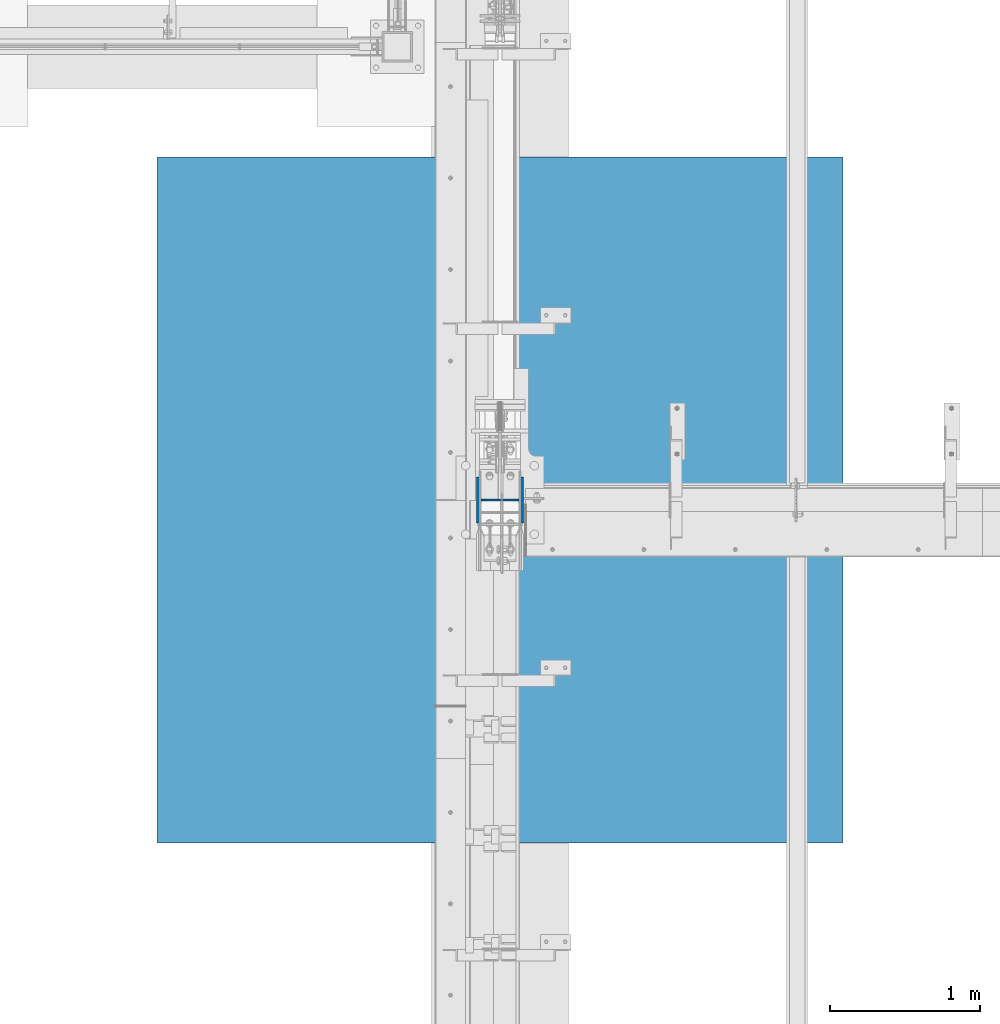
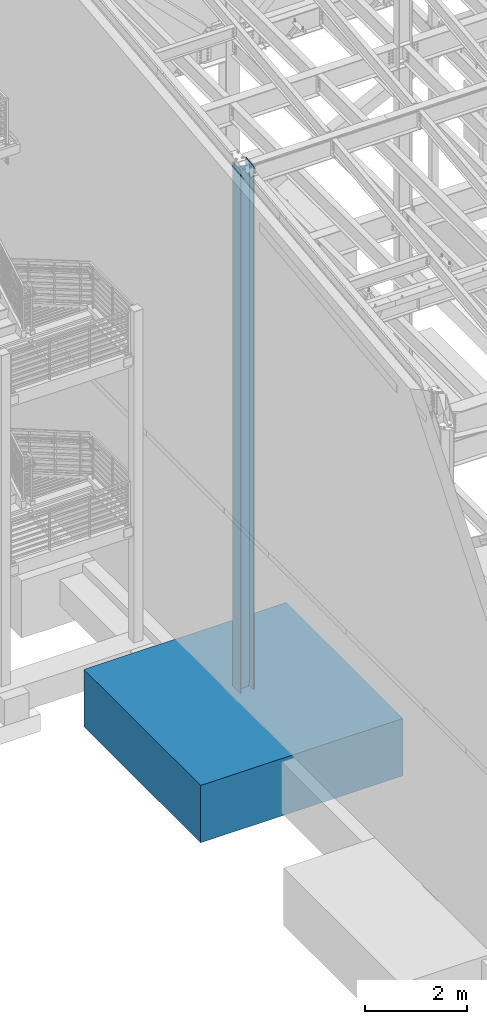
# One storey, part 357 of 1179: 2 columns, 2 elements without a shape of their own.
"""IFC2X3 building model written with IfcOpenShell, lengths in millimetres."""

import ifcopenshell
import ifcopenshell.guid

model = None  # the IFC model being written
_history = None  # IfcOwnerHistory: only IFC2X3 demands one
_inside = {}  # id of a spatial element -> (the spatial element, [elements in it])
_under = {}  # id of a project, library or spatial element -> (it, [spatial elements below it])
_declared = {}  # id of a project -> (the project, [libraries it declares])
_typed = {}  # id of a type object -> (the type object, [elements of that type])
_made_of = {}  # id of a material, layer set ... -> (it, [elements and type objects made of it])


def new_model(schema):
    """Start an empty IFC model of exactly this schema.

    Asked for "IFC4X3", IfcOpenShell would pick the latest addendum, in which some entities
    have other attributes; the version numbers below select the first issue.
    IFC2X3 requires an IfcOwnerHistory on every rooted entity: one is made here for all.
    """
    global model, _history
    if schema == "IFC4X3":
        model = ifcopenshell.file(schema_version=(4, 3, 0, 0))
    else:
        model = ifcopenshell.file(schema=schema)
    _inside.clear()
    _under.clear()
    _declared.clear()
    _typed.clear()
    _made_of.clear()
    _history = None
    if model.schema == "IFC2X3":
        org = make("IfcOrganization", Name="unknown")
        user = make(
            "IfcPersonAndOrganization",
            ThePerson=make("IfcPerson", FamilyName="unknown"),
            TheOrganization=org,
        )
        app = make(
            "IfcApplication",
            ApplicationDeveloper=org,
            Version="unknown",
            ApplicationFullName="unknown",
            ApplicationIdentifier="unknown",
        )
        _history = make(
            "IfcOwnerHistory",
            OwningUser=user,
            OwningApplication=app,
            ChangeAction="ADDED",
            CreationDate=0,
        )
    return model


def make(cls, **values):
    """One entity of the class cls with the attributes given. An attribute that is None is left unset."""
    return model.create_entity(
        cls, **{name: value for name, value in values.items() if value is not None}
    )


def rooted(cls, **values):
    """An entity with a GlobalId (a new one), such as an element, a storey or a relation."""
    return make(cls, GlobalId=ifcopenshell.guid.new(), OwnerHistory=_history, **values)


def si_unit(unit_type, name, prefix=None):
    """IfcSIUnit, for example si_unit("LENGTHUNIT", "METRE", prefix="MILLI")."""
    return make("IfcSIUnit", UnitType=unit_type, Prefix=prefix, Name=name)


def assignment(units):
    """IfcUnitAssignment: the units of a project."""
    return None if units is None else make("IfcUnitAssignment", Units=units)


def point(xyz):
    """IfcCartesianPoint."""
    return None if xyz is None else make("IfcCartesianPoint", Coordinates=xyz)


def direction(xyz):
    """IfcDirection."""
    return None if xyz is None else make("IfcDirection", DirectionRatios=xyz)


def frame(location, z_axis=None, x_axis=None):
    """IfcAxis2Placement3D, a coordinate frame: its origin and axes. An axis left out is left unset."""
    return make(
        "IfcAxis2Placement3D",
        Location=point(location),
        Axis=direction(z_axis),
        RefDirection=direction(x_axis),
    )


def origin_with_axes():
    """The frame at (0, 0, 0) with the z axis (0, 0, 1) and the x axis (1, 0, 0) written out."""
    return frame((0.0, 0.0, 0.0), z_axis=(0.0, 0.0, 1.0), x_axis=(1.0, 0.0, 0.0))


def place(relative_to, where):
    """IfcLocalPlacement: puts the frame where relative to a parent placement (None: the world)."""
    return make(
        "IfcLocalPlacement", PlacementRelTo=relative_to, RelativePlacement=where
    )


def context(
    kind, dimensions, precision=None, world=None, true_north=None, identifier=None
):
    """IfcGeometricRepresentationContext, for example the 3D "Model" context."""
    return make(
        "IfcGeometricRepresentationContext",
        ContextIdentifier=identifier,
        ContextType=kind,
        CoordinateSpaceDimension=dimensions,
        Precision=precision,
        WorldCoordinateSystem=world,
        TrueNorth=true_north,
    )


def subcontext(parent, identifier, kind, view, scale=None):
    """IfcGeometricRepresentationSubContext, for example "Body" below "Model"."""
    return make(
        "IfcGeometricRepresentationSubContext",
        ContextIdentifier=identifier,
        ContextType=kind,
        ParentContext=parent,
        TargetScale=scale,
        TargetView=view,
    )


def project(units=None, contexts=None):
    """IfcProject with its units and contexts."""
    return rooted(
        "IfcProject",
        Name="project",
        RepresentationContexts=contexts,
        UnitsInContext=assignment(units),
    )


def spatial(cls, under=None, at=None, **own):
    """A site, building, storey or space (cls), placed at a placement, below another one or the project."""
    s = rooted(cls, ObjectPlacement=at, **own)
    if under is not None:
        _under.setdefault(under.id(), (under, []))[1].append(s)
    return s


def faces_of(points, faces, orient=None, outer=None):
    """IfcFace entities. A face is a list of loops; a loop is a list of indices into points, from 0.

    orient and outer hold one flag for each loop. By default every Orientation is true, the
    first loop of a face is its IfcFaceOuterBound and the others are IfcFaceBound.
    """
    made = []
    for i, loops in enumerate(faces):
        bounds = []
        for j, loop in enumerate(loops):
            is_outer = j == 0 if outer is None else outer[i][j]
            bounds.append(
                make(
                    "IfcFaceOuterBound" if is_outer else "IfcFaceBound",
                    Bound=make("IfcPolyLoop", Polygon=[points[k] for k in loop]),
                    Orientation=True if orient is None else orient[i][j],
                )
            )
        made.append(make("IfcFace", Bounds=bounds))
    return made


def faceted_brep(points, faces, orient=None, outer=None, voids=None):
    """IfcFacetedBrep: a solid bounded by flat faces; with voids (closed shells), ...WithVoids."""
    shared = [point(p) for p in points]
    hull = make("IfcClosedShell", CfsFaces=faces_of(shared, faces, orient, outer))
    if voids is None:
        return make("IfcFacetedBrep", Outer=hull)
    return make(
        "IfcFacetedBrepWithVoids",
        Outer=hull,
        Voids=[
            make(cls, CfsFaces=faces_of(shared, fs, o, b)) for cls, fs, o, b in voids
        ],
    )


def shape(context_of_items, identifier, shape_type, items):
    """IfcShapeRepresentation: the items that make up one representation, for example the "Body"."""
    return make(
        "IfcShapeRepresentation",
        ContextOfItems=context_of_items,
        RepresentationIdentifier=identifier,
        RepresentationType=shape_type,
        Items=items,
    )


def material(Name=None, Category=None):
    """IfcMaterial."""
    return make("IfcMaterial", Name=Name, Category=Category)


def made_of(thing, what):
    """Note that an element or type object is made of a material, layer set ...; save() writes the relation."""
    if what is not None:
        _made_of.setdefault(what.id(), (what, []))[1].append(thing)
    return thing


def type_object(cls, material=None, **own):
    """A type object (cls), such as IfcWallType, which elements share."""
    return made_of(rooted(cls, **own), material)


def element(
    cls,
    number,
    at=None,
    inside=None,
    cuts=None,
    type_object=None,
    material=None,
    context=None,
    identifier="Body",
    shape_type=None,
    held_by="IfcProductDefinitionShape",
    body=None,
    shapes=None,
    **own,
):
    """One element of the class cls, such as IfcWall. Its Tag is "e" and its number.

    at: its placement. inside: the storey or other place that contains it. cuts: it is an
    opening in that element (IfcRelVoidsElement). A single representation is given by context,
    identifier, shape_type and body (its items); several are given by shapes. held_by: the class
    of the entity that holds the representations. save() writes the other relations.
    """
    e = rooted(cls, Tag="e%d" % number, ObjectPlacement=at, **own)
    if body is not None:
        shapes = [shape(context, identifier, shape_type, body)]
    if shapes is not None:
        e.Representation = make(held_by, Representations=shapes)
    if inside is not None:
        _inside.setdefault(inside.id(), (inside, []))[1].append(e)
    if cuts is not None:
        rooted(
            "IfcRelVoidsElement", RelatingBuildingElement=cuts, RelatedOpeningElement=e
        )
    if type_object is not None:
        _typed.setdefault(type_object.id(), (type_object, []))[1].append(e)
    return made_of(e, material)


def aggregate(whole, parts):
    """IfcRelAggregates: a whole, such as a stair, and the parts it consists of."""
    return rooted("IfcRelAggregates", RelatingObject=whole, RelatedObjects=parts)


def save(model, path):
    """Write the relations noted so far, then the file.

    IfcRelAggregates (storeys below a building ...), IfcRelContainedInSpatialStructure (elements
    in a storey), IfcRelDefinesByType, IfcRelAssociatesMaterial and IfcRelDeclares: one each for
    every whole, place, type object, material and project.
    """
    for whole, parts in _under.values():
        aggregate(whole, parts)
    for where, things in _inside.values():
        rooted(
            "IfcRelContainedInSpatialStructure",
            RelatedElements=things,
            RelatingStructure=where,
        )
    for kind, things in _typed.values():
        rooted("IfcRelDefinesByType", RelatedObjects=things, RelatingType=kind)
    for what, things in _made_of.values():
        rooted("IfcRelAssociatesMaterial", RelatedObjects=things, RelatingMaterial=what)
    for by, libraries in _declared.values():
        rooted("IfcRelDeclares", RelatingContext=by, RelatedDefinitions=libraries)
    model.write(path)


model = new_model("IFC2X3")

# Units and contexts
model_context = context("Model", 3, precision=1e-05, world=origin_with_axes())
body_context = subcontext(model_context, "Body", "Model", "MODEL_VIEW")
ifc_project = project(units=[si_unit("LENGTHUNIT", "METRE", prefix="MILLI"), si_unit("AREAUNIT", "SQUARE_METRE"), si_unit("VOLUMEUNIT", "CUBIC_METRE"), si_unit("MASSUNIT", "GRAM", prefix="KILO"), si_unit("TIMEUNIT", "SECOND"), si_unit("PLANEANGLEUNIT", "RADIAN"), si_unit("SOLIDANGLEUNIT", "STERADIAN"), si_unit("THERMODYNAMICTEMPERATUREUNIT", "DEGREE_CELSIUS"), si_unit("LUMINOUSINTENSITYUNIT", "LUMEN")], contexts=[model_context])

# Site, building, storey
site_placement = place(None, origin_with_axes())
site = spatial("IfcSite", under=ifc_project, at=site_placement, CompositionType="ELEMENT")
building_placement = place(site_placement, origin_with_axes())
building = spatial("IfcBuilding", under=site, at=building_placement, Name="Undefined", CompositionType="ELEMENT")
storey_placement = place(building_placement, origin_with_axes())
storey = spatial("IfcBuildingStorey", under=building, at=storey_placement, Name="Undefined", CompositionType="ELEMENT", Elevation=0.0)

# Assembly, column
assembly_1_placement = place(storey_placement, origin_with_axes())
assembly_1 = element("IfcElementAssembly", 1, at=assembly_1_placement, inside=storey, Name="FOOTING", AssemblyPlace="NOTDEFINED", PredefinedType="REINFORCEMENT_UNIT")
ifc_material_1 = material(Name="CONCRETE/3000")
column_type_1 = type_object("IfcColumnType", PredefinedType="NOTDEFINED")
column_1_placement = place(assembly_1_placement, frame((431.800000000001, 27051.0, -1727.2), z_axis=(-1.0, 0.0, 0.0), x_axis=(0.0, 0.0, 1.0)))
column_1 = element("IfcColumn", 2, at=column_1_placement, type_object=column_type_1, material=ifc_material_1, Name="FOOTING", context=body_context, shape_type="Brep", body=[
    faceted_brep([(0.0, 2286.0, -2286.0), (0.0, 2286.0, 2286.0), (1371.6, 2286.0, 2286.0), (1371.6, 2286.0, -2286.0), (0.0, -2286.0, 2286.0), (1371.6, -2286.0, 2286.0), (0.0, -2286.0, -2286.0), (1371.6, -2286.0, -2286.0)], [[[0, 1, 2, 3]], [[1, 4, 5, 2]], [[4, 6, 7, 5]], [[6, 0, 3, 7]], [[5, 7, 3, 2]], [[6, 4, 1, 0]]]),
])
aggregate(assembly_1, [column_1])

assembly_2_placement = place(storey_placement, origin_with_axes())
assembly_2 = element("IfcElementAssembly", 3, at=assembly_2_placement, inside=storey, Name="COLUMN", AssemblyPlace="NOTDEFINED", PredefinedType="RIGID_FRAME")
ifc_material_2 = material(Name="STEEL/A992")
column_type_2 = type_object("IfcColumnType", Name="W12X79", PredefinedType="NOTDEFINED")
column_2_placement = place(assembly_2_placement, frame((431.800000000001, 27051.0, -355.6), z_axis=(-1.0, 0.0, 0.0), x_axis=(0.0, 0.0, 1.0)))
column_2 = element("IfcColumn", 4, at=column_2_placement, type_object=column_type_2, material=ifc_material_2, Name="COLUMN", ObjectType="W12X79", context=body_context, shape_type="Brep", body=[
    faceted_brep([(160.223581529497, -153.987499999999, 157.1625), (160.223581529497, 153.987499999999, 157.1625), (149.225002356772, 153.987499999999, 138.1125), (149.225002356772, 6.35000012494493, 138.1125), (148.995793121516, 6.35000012313685, 137.715499999996), (148.995793121516, -6.34999999999854, 137.715499999996), (149.225002356772, -6.34999999999854, 138.1125), (149.225002356772, -153.987499999999, 138.1125), (188.913, -6.34999999999854, 137.715499999996), (188.913, 6.35000008947463, 137.715499999996), (208.49066058208, 6.35000008789211, 131.2871410688), (208.49066058208, -6.34999999999854, 131.2871410688), (212.873373738864, 6.35000008718271, 128.290736246858), (212.873373738864, -6.34999999999854, 128.290736246858), (214.971292158606, 6.35000008606585, 123.413713099926), (214.971292158606, -6.34999999999854, 123.413713099926), (214.132634973196, 6.3500000848835, 118.171264187733), (214.132634973196, -6.34999999999854, 118.171264187733), (210.617956026487, 6.35000008400311, 114.192112472459), (210.617956026487, -6.34999999999854, 114.192112472459), (205.519195059062, 6.35000008370116, 112.712499999996), (205.519195059062, -6.34999999999854, 112.712499999996), (139.700000000001, 6.34999999999854, 112.7125), (147.032309983244, -6.35000007376584, 112.7125), (139.700000000001, 6.34999999999854, -112.7125), (147.032309983244, -6.35000000747095, -112.7125), (205.519195059063, 6.3500000365857, -112.712500000003), (205.519195059063, -6.34999999999854, -112.712500000003), (210.617956026486, 6.35000003621826, -114.192112472468), (210.617956026486, -6.34999999999854, -114.192112472468), (214.132634973195, 6.35000003529422, -118.171264187741), (214.132634973195, -6.34999999999854, -118.171264187741), (214.971292158605, 6.35000003410096, -123.413713099934), (214.971292158605, -6.34999999999854, -123.413713099934), (212.873373738863, 6.35000003300956, -128.290736246865), (212.873373738863, -6.34999999999854, -128.290736246865), (208.49066058208, 6.35000003235837, -131.287141068808), (208.49066058208, -6.34999999999854, -131.287141068808), (188.913, 6.35000003102323, -137.715500000003), (188.913, -6.34999999999854, -137.715500000003), (148.99620123074, 6.35000000162472, -137.715500000003), (148.99620123074, -6.34999999999854, -137.715500000003), (12631.1641576037, 6.34999999999854, -138.1125), (12659.8533252286, 6.34999999999854, -138.1125), (12676.5267323464, 153.987499999999, -138.1125), (149.225402461476, 153.987499999999, -138.1125), (149.225402461477, 6.34999999999854, -138.1125), (12641.7456465308, -153.987499999999, -138.1125), (12641.7456465308, -153.987499999999, -157.1625), (12676.5267323464, 153.987499999999, -157.1625), (12658.4190536486, -6.34999999999854, -138.1125), (149.225402461476, -153.987499999999, -138.1125), (160.223597538519, -153.987499999999, -157.1625), (160.223597538519, 153.987499999999, -157.1625), (149.225402461476, -6.34999999999854, -138.1125), (12629.7290744425, -6.34999999999854, -138.1125), (12631.1641576037, 6.34999999999854, 138.1125), (12629.7290744425, -6.35000000018772, 138.1125), (12659.8392408815, 6.35000000022046, 138.112500001512), (12658.4190536486, -6.34999999999854, 138.1125), (12676.5267323464, 153.987499999999, 138.1125), (12676.5267323464, 153.987499999999, 157.1625), (12641.7456465308, -153.987499999999, 157.1625), (12641.7456465308, -153.987499999999, 138.1125)], [[[0, 1, 2, 3, 4, 5, 6, 7]], [[8, 9, 10, 11]], [[11, 10, 12, 13]], [[13, 12, 14, 15]], [[15, 14, 16, 17]], [[17, 16, 18, 19]], [[19, 18, 20, 21]], [[21, 20, 22, 23]], [[24, 25, 23, 22]], [[25, 24, 26, 27]], [[27, 26, 28, 29]], [[29, 28, 30, 31]], [[31, 30, 32, 33]], [[33, 32, 34, 35]], [[35, 34, 36, 37]], [[37, 36, 38, 39]], [[39, 38, 40, 41]], [[42, 43, 44, 45, 46]], [[47, 48, 49, 44, 43, 50]], [[48, 47, 51, 52]], [[49, 48, 52, 53]], [[44, 49, 53, 45]], [[52, 51, 54, 41, 40, 46, 45, 53]], [[47, 50, 55, 54, 51]], [[43, 42, 55, 50]], [[56, 57, 55, 42]], [[58, 59, 57, 56]], [[60, 61, 62, 63, 59, 58]], [[63, 62, 0, 7]], [[57, 59, 63, 7, 6]], [[8, 11, 13, 15, 17, 19, 21, 23, 25, 27, 29, 31, 33, 35, 37, 39, 41, 54, 55, 57, 6, 5]], [[9, 8, 5, 4]], [[56, 42, 46, 40, 38, 36, 34, 32, 30, 28, 26, 24, 22, 20, 18, 16, 14, 12, 10, 9, 4, 3]], [[60, 58, 56, 3, 2]], [[61, 60, 2, 1]], [[62, 61, 1, 0]]]),
])
aggregate(assembly_2, [column_2])

save(model, "model.ifc")
